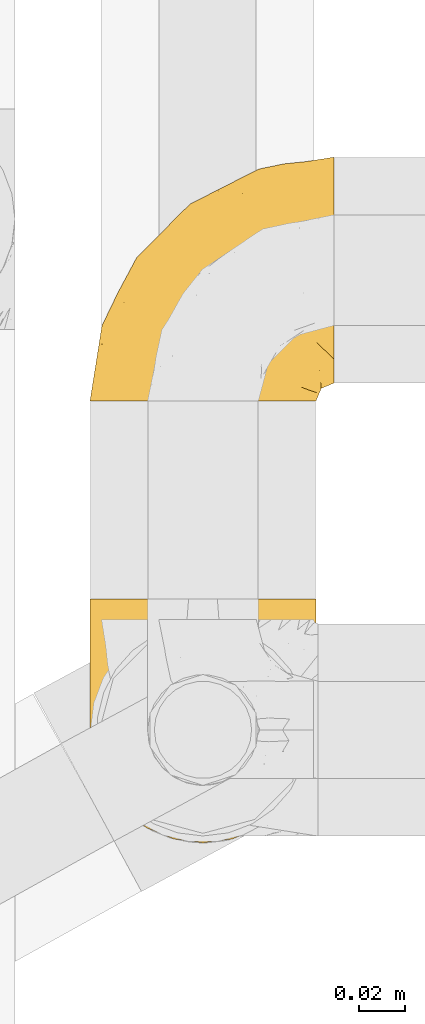
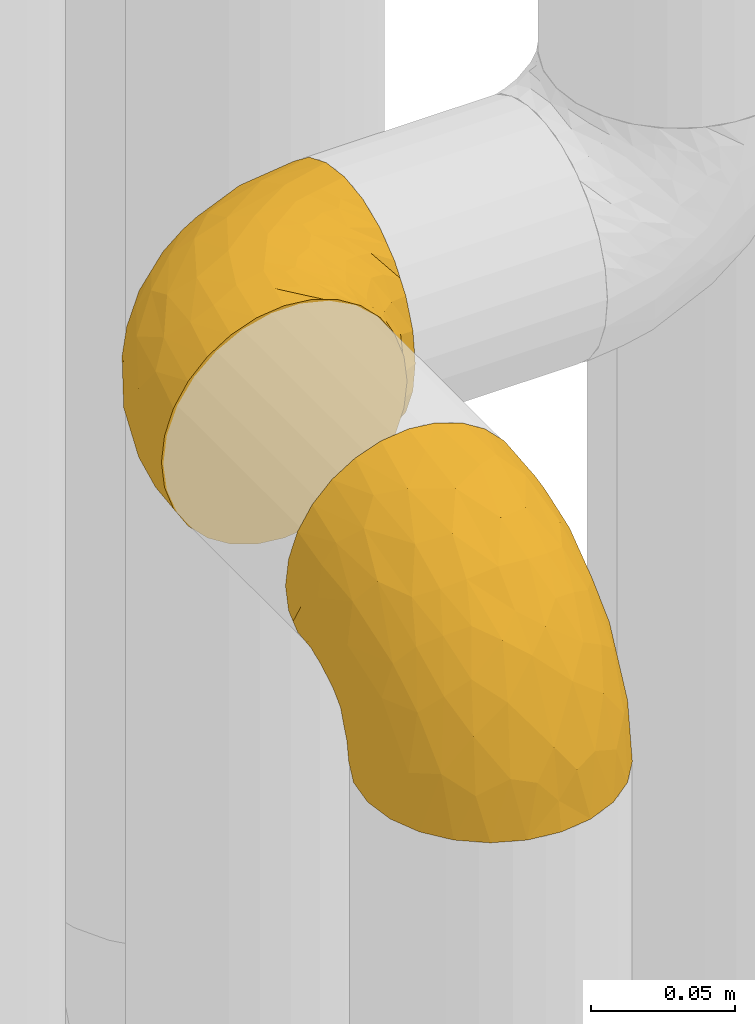
# One storey, part 147 of 827: 2 coverings.
"""IFC2X3 building model written with IfcOpenShell, lengths in millimetres."""

from ifc_helpers import new_model, entity, si_unit, converted_unit, derived_unit, direction, frame, origin, place, context, subcontext, project, spatial, faceted_brep, element, save


model = new_model("IFC2X3")

# Units and contexts
model_context = context("Model", 3, precision=0.01, world=origin(), true_north=direction((6.12303176911189e-17, 1.0)))
body_context = subcontext(model_context, "Body", "Model", "MODEL_VIEW")
ifc_project = project(units=[si_unit("LENGTHUNIT", "METRE", prefix="MILLI"), si_unit("AREAUNIT", "SQUARE_METRE"), si_unit("VOLUMEUNIT", "CUBIC_METRE"), converted_unit("PLANEANGLEUNIT", "DEGREE", entity("IfcRatioMeasure", 0.0174532925199433), si_unit("PLANEANGLEUNIT", "RADIAN"), dimensions=[0, 0, 0, 0, 0, 0, 0]), si_unit("MASSUNIT", "GRAM", prefix="KILO"), derived_unit("MASSDENSITYUNIT", [(si_unit("MASSUNIT", "GRAM", prefix="KILO"), 1), (si_unit("LENGTHUNIT", "METRE"), -3)]), derived_unit("MOMENTOFINERTIAUNIT", [(si_unit("LENGTHUNIT", "METRE"), 4)]), si_unit("TIMEUNIT", "SECOND"), si_unit("FREQUENCYUNIT", "HERTZ"), si_unit("THERMODYNAMICTEMPERATUREUNIT", "DEGREE_CELSIUS"), derived_unit("THERMALTRANSMITTANCEUNIT", [(si_unit("MASSUNIT", "GRAM", prefix="KILO"), 1), (si_unit("THERMODYNAMICTEMPERATUREUNIT", "KELVIN"), -1), (si_unit("TIMEUNIT", "SECOND"), -3)]), derived_unit("VOLUMETRICFLOWRATEUNIT", [(si_unit("LENGTHUNIT", "METRE"), 3), (si_unit("TIMEUNIT", "SECOND"), -1)]), derived_unit("MASSFLOWRATEUNIT", [(si_unit("MASSUNIT", "GRAM", prefix="KILO"), 1), (si_unit("TIMEUNIT", "SECOND"), -1)]), derived_unit("ROTATIONALFREQUENCYUNIT", [(si_unit("TIMEUNIT", "SECOND"), -1)]), si_unit("ELECTRICCURRENTUNIT", "AMPERE"), si_unit("ELECTRICVOLTAGEUNIT", "VOLT"), si_unit("POWERUNIT", "WATT"), si_unit("FORCEUNIT", "NEWTON", prefix="KILO"), si_unit("ILLUMINANCEUNIT", "LUX"), si_unit("LUMINOUSFLUXUNIT", "LUMEN"), si_unit("LUMINOUSINTENSITYUNIT", "CANDELA"), derived_unit("USERDEFINED", [(si_unit("MASSUNIT", "GRAM", prefix="KILO"), -1), (si_unit("LENGTHUNIT", "METRE"), -2), (si_unit("TIMEUNIT", "SECOND"), 3), (si_unit("LUMINOUSFLUXUNIT", "LUMEN"), 1)]), derived_unit("LINEARVELOCITYUNIT", [(si_unit("LENGTHUNIT", "METRE"), 1), (si_unit("TIMEUNIT", "SECOND"), -1)]), si_unit("PRESSUREUNIT", "PASCAL"), derived_unit("USERDEFINED", [(si_unit("LENGTHUNIT", "METRE"), -2), (si_unit("MASSUNIT", "GRAM", prefix="KILO"), 1), (si_unit("TIMEUNIT", "SECOND"), -2)]), derived_unit("LINEARFORCEUNIT", [(si_unit("MASSUNIT", "GRAM", prefix="KILO"), 1), (si_unit("LENGTHUNIT", "METRE"), 1), (si_unit("TIMEUNIT", "SECOND"), -2), (si_unit("LENGTHUNIT", "METRE"), -1)]), derived_unit("PLANARFORCEUNIT", [(si_unit("MASSUNIT", "GRAM", prefix="KILO"), 1), (si_unit("LENGTHUNIT", "METRE"), 1), (si_unit("TIMEUNIT", "SECOND"), -2), (si_unit("LENGTHUNIT", "METRE"), -2)])], contexts=[model_context])

# Site, building, storey
site_placement = place(None, origin())
site = spatial("IfcSite", under=ifc_project, at=site_placement, CompositionType="ELEMENT")
building_placement = place(site_placement, origin())
building = spatial("IfcBuilding", under=site, at=building_placement, CompositionType="ELEMENT")
storey_placement = place(building_placement, frame((0.0, 0.0, 28200.0)))
storey = spatial("IfcBuildingStorey", under=building, at=storey_placement, Name="08", CompositionType="ELEMENT", Elevation=28200.0)

# Coverings
covering_1_placement = place(storey_placement, frame((35677.3, 10555.46, 2541.4)))
element("IfcCovering", 1, at=covering_1_placement, inside=storey, Name=":ADSK_", ObjectType=":ADSK_", PredefinedType="INSULATION", context=body_context, shape_type="Brep", body=[
    faceted_brep([(1.6, 107.75, 58.6), (2.83, 107.75, 69.54), (6.47, 107.75, 79.93), (12.32, 107.75, 89.25), (20.11, 107.75, 97.03), (29.43, 107.75, 102.88), (39.81, 107.75, 106.51), (50.75, 107.75, 107.75), (61.69, 107.75, 106.51), (72.08, 107.75, 102.87), (81.4, 107.75, 97.02), (89.18, 107.75, 89.23), (95.03, 107.75, 79.91), (98.66, 107.75, 69.53), (99.9, 107.75, 58.6), (99.25, 107.75, 52.89), (98.66, 107.75, 47.65), (96.84, 107.75, 42.46), (95.02, 107.75, 37.26), (89.17, 107.75, 27.94), (81.38, 107.75, 20.16), (72.06, 107.75, 14.31), (61.68, 107.75, 10.68), (50.75, 107.75, 9.45), (39.8, 107.75, 10.68), (29.41, 107.75, 14.32), (20.09, 107.75, 20.17), (12.31, 107.75, 27.96), (6.46, 107.75, 37.28), (4.64, 107.75, 42.47), (2.83, 107.75, 47.66), (2.24, 107.75, 52.89), (1.92, 107.75, 55.75), (63.47, 98.22, 1.6), (75.32, 93.31, 1.6), (80.41, 89.4, 1.6), (85.5, 85.5, 1.6), (89.4, 80.41, 1.6), (93.31, 75.32, 1.6), (95.77, 69.39, 1.6), (98.22, 63.47, 1.6), (99.14, 56.48, 1.6), (99.52, 53.61, 1.6), (99.9, 50.75, 1.6), (98.22, 38.02, 1.6), (93.31, 26.17, 1.6), (85.5, 15.99, 1.6), (75.32, 8.18, 1.6), (63.47, 3.27, 1.6), (50.75, 1.6, 1.6), (38.02, 3.27, 1.6), (26.17, 8.18, 1.6), (15.99, 15.99, 1.6), (8.18, 26.17, 1.6), (3.27, 38.02, 1.6), (1.6, 50.75, 1.6), (2.35, 56.48, 1.6), (3.27, 63.47, 1.6), (5.73, 69.39, 1.6), (8.18, 75.32, 1.6), (12.09, 80.41, 1.6), (15.99, 85.5, 1.6), (21.08, 89.4, 1.6), (26.17, 93.31, 1.6), (38.02, 98.22, 1.6), (50.75, 99.9, 1.6), (42.18, 27.53, 69.96), (28.42, 25.32, 59.59), (37.78, 16.29, 51.96), (50.75, 6.79, 34.4), (42.85, 4.51, 23.37), (50.75, 3.51, 13.68), (24.75, 17.47, 41.52), (33.81, 7.6, 26.26), (22.57, 12.27, 20.18), (7.18, 70.89, 72.33), (2.73, 87.17, 65.88), (3.09, 67.3, 57.55), (6.92, 31.65, 23.76), (11.58, 33.58, 46.5), (5.17, 47.23, 46.57), (2.71, 43.26, 21.17), (1.6, 55.08, 23.41), (1.6, 53.99, 17.92), (1.6, 52.9, 12.43), (1.6, 52.36, 9.72), (1.6, 51.82, 7.01), (14.18, 21.5, 26.77), (5.88, 89.94, 76.59), (41.06, 60.45, 95.55), (36.25, 83.0, 102.57), (28.62, 64.79, 92.89), (1.6, 85.93, 54.26), (1.6, 81.31, 51.17), (1.6, 76.69, 48.08), (1.6, 72.06, 44.99), (1.6, 67.44, 41.9), (10.85, 88.74, 85.16), (38.35, 45.98, 85.97), (9.6, 47.13, 59.58), (26.24, 89.4, 99.5), (50.75, 95.66, 105.83), (19.31, 28.5, 53.59), (16.41, 42.81, 67.0), (24.56, 38.28, 71.56), (50.75, 45.35, 87.47), (50.75, 33.61, 75.73), (18.47, 82.57, 92.24), (1.6, 105.04, 58.06), (1.6, 102.33, 57.52), (1.6, 96.91, 56.44), (1.6, 91.42, 55.35), (14.36, 65.92, 81.33), (20.64, 53.11, 80.35), (2.32, 54.37, 39.44), (50.75, 74.94, 102.55), (1.6, 64.35, 37.28), (1.6, 61.26, 32.65), (1.6, 58.17, 28.03), (50.75, 21.87, 63.99), (33.88, 34.79, 74.55), (29.24, 48.48, 83.62), (50.75, 60.15, 95.01), (50.75, 14.33, 49.19), (2.8, 99.07, 46.96), (2.48, 60.55, 8.77), (2.7, 64.18, 18.28), (3.2, 64.36, 11.68), (32.98, 103.17, 11.79), (24.67, 101.69, 15.69), (2.95, 87.75, 42.49), (2.19, 89.38, 47.41), (17.92, 88.34, 7.94), (12.02, 82.14, 9.27), (25.73, 94.51, 7.98), (16.63, 89.64, 13.4), (25.6, 98.41, 13.04), (36.72, 99.71, 7.36), (10.66, 89.37, 23.46), (6.87, 88.21, 30.46), (11.12, 95.2, 26.54), (10.31, 79.14, 6.76), (12.84, 101.22, 26.46), (17.38, 99.41, 20.77), (9.74, 84.72, 20.68), (4.63, 97.47, 40.26), (50.75, 102.19, 7.15), (42.52, 104.02, 9.28), (3.12, 82.66, 38.78), (17.58, 95.42, 18.27), (3.97, 78.67, 31.78), (5.94, 72.69, 12.75), (2.73, 66.46, 22.96), (6.23, 75.3, 17.55), (3.45, 72.74, 27.63), (10.84, 82.93, 15.23), (7.98, 99.27, 33.25), (7.33, 93.51, 32.43), (2.39, 67.35, 27.9), (75.76, 94.51, 7.97), (90.65, 82.94, 15.22), (83.57, 88.33, 7.93), (84.85, 89.64, 13.38), (71.05, 103.62, 13.12), (98.54, 87.74, 42.49), (99.3, 89.38, 47.4), (99.9, 81.31, 51.17), (96.86, 97.47, 40.24), (84.1, 99.41, 20.76), (99.9, 52.9, 12.43), (99.9, 51.82, 7.01), (99.9, 51.28, 4.31), (88.63, 101.21, 26.44), (90.36, 95.19, 26.52), (98.29, 64.36, 11.68), (95.55, 72.69, 12.75), (89.47, 82.13, 9.27), (95.26, 75.3, 17.55), (91.18, 79.14, 6.76), (93.49, 99.28, 33.21), (94.15, 93.51, 32.41), (99.01, 60.55, 8.77), (98.76, 66.46, 22.96), (98.85, 63.96, 18.48), (99.9, 96.91, 56.44), (98.69, 99.06, 46.95), (64.78, 99.7, 7.36), (99.9, 53.99, 17.92), (99.9, 55.08, 23.41), (62.91, 103.3, 9.85), (99.9, 102.33, 57.52), (99.9, 99.62, 56.98), (99.9, 76.69, 48.08), (98.37, 82.66, 38.78), (83.9, 95.42, 18.25), (99.9, 72.06, 44.99), (97.51, 78.68, 31.74), (94.62, 88.2, 30.45), (98.04, 72.75, 27.63), (91.73, 84.74, 20.65), (99.9, 91.42, 55.35), (99.9, 85.93, 54.26), (75.87, 98.41, 13.03), (90.83, 89.37, 23.44), (99.1, 67.35, 27.9), (99.9, 61.26, 32.65), (99.9, 58.17, 28.03), (99.9, 64.35, 37.28), (99.9, 67.44, 41.9), (99.09, 54.08, 39.74), (58.64, 4.51, 23.37), (87.31, 21.5, 26.77), (89.93, 33.43, 46.18), (82.22, 28.5, 53.54), (76.74, 17.47, 41.53), (73.12, 25.36, 59.61), (95.54, 90.18, 76.79), (98.7, 86.97, 66.11), (98.79, 43.26, 21.17), (63.71, 16.29, 51.96), (67.68, 7.6, 26.26), (78.92, 12.27, 20.18), (94.57, 31.65, 23.76), (72.88, 64.79, 92.88), (65.25, 83.0, 102.57), (60.44, 60.44, 95.54), (76.94, 38.35, 71.63), (67.61, 34.8, 74.55), (94.38, 71.54, 72.51), (59.31, 27.53, 69.96), (83.03, 82.57, 92.23), (90.66, 88.74, 85.15), (80.8, 53.19, 80.45), (72.22, 48.49, 83.65), (98.39, 67.28, 57.57), (92.31, 52.32, 63.68), (63.11, 45.94, 85.95), (75.27, 89.4, 99.49), (87.15, 65.75, 81.23), (96.03, 46.73, 47.07), (85.1, 42.82, 66.99)], [[[0, 1, 2, 3, 4, 5, 6, 7, 8, 9, 10, 11, 12, 13, 14, 15, 16, 17, 18, 19, 20, 21, 22, 23, 24, 25, 26, 27, 28, 29, 30, 31, 32]], [[33, 34, 35, 36, 37, 38, 39, 40, 41, 42, 43, 44, 45, 46, 47, 48, 49, 50, 51, 52, 53, 54, 55, 56, 57, 58, 59, 60, 61, 62, 63, 64, 65]], [[66, 67, 68]], [[69, 70, 71]], [[68, 72, 73]], [[73, 72, 74]], [[75, 76, 77]], [[78, 79, 80]], [[51, 50, 73]], [[81, 82, 83, 84, 85, 86, 55]], [[52, 87, 53]], [[74, 52, 51]], [[2, 1, 88]], [[89, 90, 91]], [[77, 92, 93, 94, 95, 96]], [[55, 54, 81]], [[78, 53, 87]], [[5, 90, 6]], [[88, 76, 75]], [[97, 3, 2]], [[89, 91, 98]], [[99, 80, 79]], [[90, 5, 100]], [[74, 87, 52]], [[100, 5, 4]], [[90, 101, 6]], [[79, 102, 103]], [[102, 67, 104]], [[105, 98, 106]], [[107, 4, 3]], [[76, 0, 108, 109, 110, 111, 92]], [[107, 112, 113]], [[114, 77, 96]], [[89, 115, 90]], [[114, 96, 116, 117, 118, 82]], [[75, 97, 88]], [[119, 66, 68]], [[50, 71, 70]], [[100, 91, 90]], [[99, 77, 80]], [[102, 104, 103]], [[97, 107, 3]], [[80, 81, 78]], [[107, 97, 112]], [[68, 73, 70]], [[66, 98, 120]], [[78, 81, 54]], [[114, 81, 80]], [[53, 78, 54]], [[78, 87, 79]], [[102, 87, 72]], [[79, 103, 99]], [[4, 107, 100]], [[91, 100, 107]], [[88, 97, 2]], [[112, 97, 75]], [[99, 112, 75]], [[103, 104, 113]], [[91, 121, 98]], [[89, 105, 122, 115]], [[101, 90, 115]], [[101, 7, 6]], [[88, 1, 76]], [[0, 76, 1]], [[92, 77, 76]], [[73, 74, 51]], [[87, 74, 72]], [[81, 114, 82]], [[77, 114, 80]], [[87, 102, 79]], [[67, 102, 72]], [[68, 67, 72]], [[67, 120, 104]], [[120, 121, 104]], [[104, 121, 113]], [[121, 120, 98]], [[91, 107, 113]], [[91, 113, 121]], [[103, 113, 112]], [[106, 98, 66]], [[105, 89, 98]], [[106, 66, 119]], [[67, 66, 120]], [[68, 69, 123, 119]], [[50, 49, 71]], [[50, 70, 73]], [[112, 99, 103]], [[77, 99, 75]], [[69, 68, 70]], [[29, 124, 110]], [[84, 83, 125]], [[126, 82, 118]], [[59, 58, 127]], [[25, 128, 129]], [[130, 93, 131]], [[132, 62, 133]], [[134, 135, 136]], [[137, 65, 64]], [[64, 134, 137]], [[138, 139, 140]], [[111, 110, 124, 92]], [[134, 136, 137]], [[134, 64, 63]], [[141, 61, 60]], [[125, 58, 57]], [[142, 143, 140]], [[142, 26, 143]], [[127, 83, 82]], [[28, 124, 29]], [[108, 0, 32, 31, 30, 110, 109]], [[30, 29, 110]], [[135, 144, 138]], [[28, 145, 124]], [[57, 56, 55, 86, 85, 84]], [[146, 147, 23]], [[24, 23, 147]], [[25, 143, 26]], [[95, 94, 148]], [[24, 128, 25]], [[149, 138, 143]], [[124, 145, 131]], [[127, 58, 125]], [[150, 148, 139]], [[127, 126, 151]], [[151, 59, 127]], [[152, 151, 126]], [[153, 154, 155]], [[153, 133, 141]], [[145, 28, 27]], [[142, 156, 27]], [[157, 148, 130]], [[61, 133, 62]], [[134, 132, 135]], [[147, 128, 24]], [[65, 137, 146]], [[146, 137, 147]], [[128, 137, 136]], [[137, 128, 147]], [[128, 136, 129]], [[149, 129, 136]], [[25, 129, 143]], [[158, 152, 117]], [[152, 118, 117]], [[153, 151, 152]], [[158, 116, 154]], [[144, 150, 138]], [[153, 152, 158]], [[133, 153, 155]], [[133, 155, 132]], [[141, 60, 151]], [[135, 132, 155]], [[134, 63, 132]], [[144, 135, 155]], [[135, 138, 149]], [[155, 154, 144]], [[150, 154, 96]], [[154, 150, 144]], [[148, 94, 130]], [[82, 126, 127]], [[118, 152, 126]], [[150, 96, 95]], [[139, 148, 157]], [[150, 95, 148]], [[93, 92, 131]], [[130, 145, 156]], [[130, 94, 93]], [[84, 125, 57]], [[127, 125, 83]], [[140, 139, 157]], [[150, 139, 138]], [[140, 157, 142]], [[138, 140, 143]], [[156, 142, 157]], [[27, 26, 142]], [[130, 156, 157]], [[145, 27, 156]], [[132, 63, 62]], [[124, 131, 92]], [[130, 131, 145]], [[129, 149, 143]], [[135, 149, 136]], [[153, 141, 151]], [[59, 151, 60]], [[133, 61, 141]], [[116, 96, 154]], [[153, 158, 154]], [[158, 117, 116]], [[34, 33, 159]], [[160, 161, 162]], [[22, 21, 163]], [[164, 165, 166]], [[19, 18, 167]], [[168, 21, 20]], [[42, 41, 40, 169, 170, 171, 43]], [[172, 173, 168]], [[174, 38, 175]], [[176, 177, 178]], [[179, 164, 180]], [[40, 181, 169]], [[182, 183, 175]], [[17, 184, 185]], [[65, 146, 186]], [[187, 174, 188]], [[23, 22, 189]], [[174, 39, 38]], [[15, 14, 190, 191, 184, 16]], [[181, 40, 39]], [[192, 193, 164]], [[194, 163, 168]], [[33, 186, 159]], [[180, 173, 172]], [[195, 196, 193]], [[18, 185, 167]], [[173, 180, 197]], [[198, 199, 196]], [[200, 201, 185, 184]], [[184, 17, 16]], [[18, 17, 185]], [[202, 159, 186]], [[194, 168, 203]], [[189, 163, 202]], [[204, 205, 182]], [[187, 181, 174]], [[160, 177, 176]], [[206, 183, 182]], [[206, 182, 205]], [[201, 165, 185]], [[165, 164, 167]], [[172, 179, 180]], [[202, 194, 162]], [[176, 161, 160]], [[65, 186, 33]], [[163, 189, 22]], [[175, 177, 182]], [[174, 183, 188]], [[177, 198, 204]], [[199, 160, 162]], [[198, 207, 204]], [[175, 38, 37]], [[198, 177, 160]], [[178, 177, 175]], [[176, 35, 161]], [[34, 159, 161]], [[162, 161, 159]], [[202, 162, 159]], [[199, 162, 203]], [[196, 199, 203]], [[198, 160, 199]], [[193, 197, 180]], [[208, 198, 196]], [[188, 183, 206]], [[175, 183, 174]], [[193, 192, 195]], [[195, 208, 196]], [[197, 196, 203]], [[180, 164, 193]], [[168, 163, 21]], [[166, 165, 201]], [[166, 192, 164]], [[189, 202, 186]], [[186, 146, 189]], [[23, 189, 146]], [[174, 181, 39]], [[169, 181, 187]], [[196, 197, 193]], [[173, 203, 168]], [[203, 173, 197]], [[172, 168, 20]], [[20, 19, 172]], [[179, 172, 19]], [[19, 167, 179]], [[164, 179, 167]], [[35, 176, 36]], [[35, 34, 161]], [[185, 165, 167]], [[162, 194, 203]], [[163, 194, 202]], [[176, 178, 36]], [[37, 36, 178]], [[175, 37, 178]], [[177, 204, 182]], [[207, 198, 208]], [[207, 205, 204]], [[209, 188, 206, 205, 207, 208]], [[48, 210, 71]], [[211, 212, 213]], [[214, 213, 215]], [[216, 217, 13]], [[218, 43, 171, 170, 169, 187, 188]], [[219, 220, 214]], [[47, 46, 221]], [[210, 48, 220]], [[211, 222, 212]], [[222, 45, 44]], [[221, 220, 47]], [[47, 220, 48]], [[221, 211, 214]], [[223, 224, 225]], [[211, 46, 45]], [[226, 227, 215]], [[43, 218, 44]], [[217, 216, 228]], [[219, 215, 229]], [[14, 13, 217]], [[224, 9, 8]], [[10, 230, 11]], [[11, 231, 12]], [[232, 223, 233]], [[234, 208, 195, 192, 166, 201]], [[235, 234, 228]], [[222, 44, 218]], [[106, 229, 236]], [[224, 237, 9]], [[231, 238, 228]], [[9, 237, 10]], [[115, 224, 101]], [[239, 234, 235]], [[231, 11, 230]], [[223, 230, 237]], [[224, 8, 101]], [[223, 236, 233]], [[225, 115, 122, 105]], [[216, 12, 231]], [[209, 234, 239]], [[210, 219, 69]], [[219, 214, 215]], [[229, 119, 219]], [[209, 218, 188]], [[239, 212, 222]], [[239, 222, 218]], [[45, 222, 211]], [[235, 212, 239]], [[213, 212, 240]], [[223, 237, 224]], [[230, 10, 237]], [[238, 231, 230]], [[216, 231, 228]], [[232, 230, 223]], [[235, 238, 240]], [[115, 225, 224]], [[233, 236, 227]], [[8, 7, 101]], [[234, 209, 208]], [[218, 209, 239]], [[217, 228, 234]], [[13, 12, 216]], [[234, 201, 217]], [[217, 201, 200, 184, 191, 190, 14]], [[211, 221, 46]], [[220, 221, 214]], [[71, 210, 69]], [[71, 49, 48]], [[219, 210, 220]], [[226, 215, 213]], [[211, 213, 214]], [[226, 213, 240]], [[215, 227, 229]], [[232, 240, 238]], [[233, 227, 226]], [[232, 233, 226]], [[236, 223, 225]], [[240, 232, 226]], [[232, 238, 230]], [[225, 105, 236]], [[236, 105, 106]], [[236, 229, 227]], [[123, 69, 219, 119]], [[106, 119, 229]], [[238, 235, 228]], [[212, 235, 240]]]),
])
covering_2_placement = place(storey_placement, frame((35677.3, 10747.61, 2549.25)))
element("IfcCovering", 2, at=covering_2_placement, inside=storey, Name=":ADSK_", ObjectType=":ADSK_", PredefinedType="INSULATION", context=body_context, shape_type="Brep", body=[
    faceted_brep([(50.75, 1.6, 99.9), (39.8, 1.6, 98.66), (29.41, 1.6, 95.02), (20.09, 1.6, 89.17), (12.31, 1.6, 81.38), (6.46, 1.6, 72.06), (2.83, 1.6, 61.68), (1.6, 1.6, 50.75), (2.83, 1.6, 39.8), (6.47, 1.6, 29.41), (12.32, 1.6, 20.09), (20.11, 1.6, 12.31), (29.43, 1.6, 6.46), (39.81, 1.6, 2.83), (50.75, 1.6, 1.6), (56.45, 1.6, 2.24), (61.69, 1.6, 2.83), (66.88, 1.6, 4.65), (72.08, 1.6, 6.47), (81.4, 1.6, 12.32), (89.18, 1.6, 20.11), (95.03, 1.6, 29.43), (98.66, 1.6, 39.81), (99.9, 1.6, 50.75), (98.66, 1.6, 61.69), (95.02, 1.6, 72.08), (89.17, 1.6, 81.4), (81.38, 1.6, 89.18), (72.06, 1.6, 95.03), (66.87, 1.6, 96.85), (61.68, 1.6, 98.66), (56.45, 1.6, 99.25), (53.6, 1.6, 99.57), (107.75, 11.12, 38.02), (107.75, 16.03, 26.17), (107.75, 19.94, 21.08), (107.75, 23.84, 15.99), (107.75, 28.93, 12.09), (107.75, 34.02, 8.18), (107.75, 39.95, 5.73), (107.75, 45.87, 3.27), (107.75, 52.86, 2.35), (107.75, 55.73, 1.97), (107.75, 58.6, 1.6), (107.75, 71.32, 3.27), (107.75, 83.17, 8.18), (107.75, 93.35, 15.99), (107.75, 101.16, 26.17), (107.75, 106.07, 38.02), (107.75, 107.75, 50.75), (107.75, 106.07, 63.47), (107.75, 101.16, 75.32), (107.75, 93.35, 85.5), (107.75, 83.17, 93.31), (107.75, 71.32, 98.22), (107.75, 58.6, 99.9), (107.75, 52.86, 99.14), (107.75, 45.87, 98.22), (107.75, 39.95, 95.77), (107.75, 34.02, 93.31), (107.75, 28.93, 89.4), (107.75, 23.84, 85.5), (107.75, 19.94, 80.41), (107.75, 16.03, 75.32), (107.75, 11.12, 63.47), (107.75, 9.45, 50.75), (39.38, 81.82, 59.31), (49.75, 84.02, 73.08), (57.38, 93.05, 63.72), (74.94, 102.55, 50.75), (85.97, 104.83, 58.64), (95.66, 105.83, 50.75), (67.82, 91.87, 76.74), (83.09, 101.74, 67.68), (89.16, 97.07, 78.92), (37.01, 38.45, 94.31), (43.46, 22.17, 98.76), (51.79, 42.04, 98.4), (85.58, 77.69, 94.57), (62.84, 75.76, 89.91), (62.77, 62.11, 96.32), (88.17, 66.08, 98.79), (85.93, 54.26, 99.9), (91.42, 55.35, 99.9), (96.91, 56.44, 99.9), (99.62, 56.98, 99.9), (102.33, 57.52, 99.9), (82.57, 87.84, 87.31), (32.75, 19.41, 95.61), (13.79, 48.89, 60.43), (6.77, 26.34, 65.24), (16.46, 44.55, 72.87), (55.08, 23.41, 99.9), (58.17, 28.03, 99.9), (61.26, 32.65, 99.9), (64.35, 37.28, 99.9), (67.44, 41.9, 99.9), (24.18, 20.6, 90.65), (23.37, 63.36, 63.14), (49.76, 62.21, 91.89), (9.84, 19.94, 75.25), (3.51, 13.68, 50.75), (55.75, 80.85, 82.18), (42.34, 66.53, 85.08), (37.78, 71.06, 76.93), (21.87, 63.99, 50.75), (33.61, 75.73, 50.75), (17.1, 26.77, 83.02), (51.28, 4.31, 99.9), (51.82, 7.01, 99.9), (52.9, 12.43, 99.9), (53.99, 17.92, 99.9), (28.01, 43.43, 87.13), (28.99, 56.23, 80.85), (69.9, 54.97, 99.17), (6.79, 34.4, 50.75), (72.06, 44.99, 99.9), (76.69, 48.08, 99.9), (81.31, 51.17, 99.9), (45.35, 87.47, 50.75), (34.79, 74.55, 67.61), (25.72, 60.86, 72.25), (14.33, 49.19, 50.75), (60.15, 95.01, 50.75), (62.38, 10.27, 98.69), (100.57, 48.79, 99.01), (91.06, 45.16, 98.79), (97.66, 44.99, 98.29), (97.55, 6.17, 68.51), (93.65, 7.65, 76.82), (66.85, 21.59, 98.54), (61.93, 19.96, 99.3), (101.4, 21.0, 83.57), (100.07, 27.2, 89.47), (101.36, 14.83, 75.76), (95.94, 19.7, 84.86), (96.3, 10.93, 75.89), (101.98, 9.63, 64.77), (85.88, 19.97, 90.83), (78.88, 21.13, 94.62), (82.8, 14.14, 90.37), (102.58, 30.2, 91.18), (82.88, 8.12, 88.65), (88.57, 9.93, 84.11), (88.67, 24.62, 91.75), (69.08, 11.87, 96.86), (102.19, 7.15, 50.75), (100.06, 5.32, 58.97), (70.56, 26.68, 98.37), (91.07, 13.92, 83.91), (77.56, 30.67, 97.52), (96.59, 36.65, 95.55), (86.38, 42.89, 98.76), (91.79, 34.04, 95.26), (81.71, 36.6, 98.04), (94.11, 26.41, 90.65), (76.09, 10.07, 93.51), (76.91, 15.83, 94.16), (81.44, 41.99, 99.1), (101.37, 14.83, 25.73), (94.12, 26.4, 10.84), (101.41, 21.01, 17.92), (95.96, 19.71, 16.64), (96.22, 5.72, 30.44), (66.85, 21.6, 2.95), (61.94, 19.96, 2.19), (58.17, 28.03, 1.6), (69.1, 11.87, 4.63), (88.58, 9.93, 17.39), (96.91, 56.44, 1.6), (102.33, 57.52, 1.6), (105.04, 58.06, 1.6), (82.9, 8.13, 12.86), (82.82, 14.15, 11.13), (97.66, 44.99, 3.2), (96.59, 36.65, 5.94), (100.07, 27.21, 12.02), (91.79, 34.04, 6.23), (102.58, 30.2, 10.31), (76.13, 10.06, 8.0), (76.93, 15.83, 7.34), (100.57, 48.79, 2.48), (86.38, 42.89, 2.73), (90.86, 45.38, 2.64), (52.9, 12.43, 1.6), (62.39, 10.28, 2.8), (101.98, 9.64, 36.71), (91.42, 55.35, 1.6), (85.93, 54.26, 1.6), (99.49, 6.05, 38.59), (51.82, 7.01, 1.6), (52.36, 9.72, 1.6), (61.26, 32.65, 1.6), (70.56, 26.68, 3.12), (91.09, 13.92, 17.59), (64.35, 37.28, 1.6), (77.6, 30.66, 3.98), (78.89, 21.14, 6.87), (81.71, 36.59, 3.45), (88.69, 24.6, 9.76), (53.99, 17.92, 1.6), (55.08, 23.41, 1.6), (96.31, 10.93, 25.62), (85.9, 19.97, 10.67), (81.45, 41.99, 2.39), (76.69, 48.08, 1.6), (81.31, 51.17, 1.6), (72.06, 44.99, 1.6), (67.44, 41.9, 1.6), (69.6, 55.26, 2.4), (85.97, 104.83, 42.85), (82.57, 87.84, 14.18), (63.16, 75.91, 11.56), (55.81, 80.84, 19.27), (67.81, 91.87, 24.75), (49.73, 83.98, 28.37), (32.55, 19.16, 5.95), (43.23, 22.37, 2.79), (88.17, 66.08, 2.71), (57.38, 93.05, 37.78), (83.08, 101.74, 33.81), (89.16, 97.07, 22.57), (85.58, 77.69, 6.92), (16.46, 44.55, 28.61), (6.77, 26.34, 36.24), (13.8, 48.9, 41.05), (37.71, 70.99, 24.55), (34.8, 74.55, 33.88), (36.83, 37.8, 7.11), (39.38, 81.82, 42.18), (17.12, 26.77, 18.46), (24.19, 20.6, 10.84), (28.89, 56.15, 20.69), (25.69, 60.85, 29.27), (51.77, 42.06, 3.1), (45.66, 57.03, 9.18), (23.39, 63.4, 38.38), (9.85, 19.94, 26.23), (28.11, 43.59, 14.34), (62.27, 62.61, 5.46), (42.35, 66.52, 16.39)], [[[0, 1, 2, 3, 4, 5, 6, 7, 8, 9, 10, 11, 12, 13, 14, 15, 16, 17, 18, 19, 20, 21, 22, 23, 24, 25, 26, 27, 28, 29, 30, 31, 32]], [[33, 34, 35, 36, 37, 38, 39, 40, 41, 42, 43, 44, 45, 46, 47, 48, 49, 50, 51, 52, 53, 54, 55, 56, 57, 58, 59, 60, 61, 62, 63, 64, 65]], [[66, 67, 68]], [[69, 70, 71]], [[68, 72, 73]], [[73, 72, 74]], [[75, 76, 77]], [[78, 79, 80]], [[51, 50, 73]], [[81, 82, 83, 84, 85, 86, 55]], [[52, 87, 53]], [[74, 52, 51]], [[2, 1, 88]], [[89, 90, 91]], [[77, 92, 93, 94, 95, 96]], [[55, 54, 81]], [[78, 53, 87]], [[5, 90, 6]], [[88, 76, 75]], [[97, 3, 2]], [[89, 91, 98]], [[99, 80, 79]], [[90, 5, 100]], [[74, 87, 52]], [[100, 5, 4]], [[90, 101, 6]], [[79, 102, 103]], [[102, 67, 104]], [[105, 98, 106]], [[107, 4, 3]], [[76, 0, 108, 109, 110, 111, 92]], [[107, 112, 113]], [[114, 77, 96]], [[89, 115, 90]], [[114, 96, 116, 117, 118, 82]], [[75, 97, 88]], [[119, 66, 68]], [[50, 71, 70]], [[100, 91, 90]], [[99, 77, 80]], [[102, 104, 103]], [[97, 107, 3]], [[80, 81, 78]], [[107, 97, 112]], [[68, 73, 70]], [[66, 98, 120]], [[78, 81, 54]], [[114, 81, 80]], [[53, 78, 54]], [[78, 87, 79]], [[102, 87, 72]], [[79, 103, 99]], [[4, 107, 100]], [[91, 100, 107]], [[88, 97, 2]], [[112, 97, 75]], [[99, 112, 75]], [[103, 104, 113]], [[91, 121, 98]], [[89, 105, 122, 115]], [[101, 90, 115]], [[101, 7, 6]], [[88, 1, 76]], [[0, 76, 1]], [[92, 77, 76]], [[73, 74, 51]], [[87, 74, 72]], [[81, 114, 82]], [[77, 114, 80]], [[87, 102, 79]], [[67, 102, 72]], [[68, 67, 72]], [[67, 120, 104]], [[120, 121, 104]], [[104, 121, 113]], [[121, 120, 98]], [[91, 107, 113]], [[91, 113, 121]], [[103, 113, 112]], [[106, 98, 66]], [[105, 89, 98]], [[106, 66, 119]], [[67, 66, 120]], [[68, 69, 123, 119]], [[50, 49, 71]], [[50, 70, 73]], [[112, 99, 103]], [[77, 99, 75]], [[69, 68, 70]], [[29, 124, 110]], [[84, 83, 125]], [[126, 82, 118]], [[59, 58, 127]], [[25, 128, 129]], [[130, 93, 131]], [[132, 62, 133]], [[134, 135, 136]], [[137, 65, 64]], [[64, 134, 137]], [[138, 139, 140]], [[111, 110, 124, 92]], [[134, 136, 137]], [[134, 64, 63]], [[141, 61, 60]], [[125, 58, 57]], [[142, 143, 140]], [[142, 26, 143]], [[127, 83, 82]], [[28, 124, 29]], [[108, 0, 32, 31, 30, 110, 109]], [[30, 29, 110]], [[135, 144, 138]], [[28, 145, 124]], [[57, 56, 55, 86, 85, 84]], [[146, 147, 23]], [[24, 23, 147]], [[25, 143, 26]], [[95, 94, 148]], [[24, 128, 25]], [[149, 138, 143]], [[124, 145, 131]], [[127, 58, 125]], [[150, 148, 139]], [[127, 126, 151]], [[151, 59, 127]], [[152, 151, 126]], [[153, 154, 155]], [[153, 133, 141]], [[145, 28, 27]], [[142, 156, 27]], [[157, 148, 130]], [[61, 133, 62]], [[134, 132, 135]], [[147, 128, 24]], [[65, 137, 146]], [[146, 137, 147]], [[128, 137, 136]], [[137, 128, 147]], [[128, 136, 129]], [[149, 129, 136]], [[25, 129, 143]], [[158, 152, 117]], [[152, 118, 117]], [[153, 151, 152]], [[158, 116, 154]], [[144, 150, 138]], [[153, 152, 158]], [[133, 153, 155]], [[133, 155, 132]], [[60, 151, 141]], [[135, 132, 155]], [[134, 63, 132]], [[144, 135, 155]], [[135, 138, 149]], [[155, 154, 144]], [[150, 154, 96]], [[154, 150, 144]], [[148, 94, 130]], [[82, 126, 127]], [[118, 152, 126]], [[150, 96, 95]], [[139, 148, 157]], [[150, 95, 148]], [[93, 92, 131]], [[130, 145, 156]], [[130, 94, 93]], [[84, 125, 57]], [[127, 125, 83]], [[140, 139, 157]], [[150, 139, 138]], [[140, 157, 142]], [[138, 140, 143]], [[156, 142, 157]], [[27, 26, 142]], [[130, 156, 157]], [[145, 27, 156]], [[132, 63, 62]], [[124, 131, 92]], [[130, 131, 145]], [[129, 149, 143]], [[135, 149, 136]], [[141, 133, 61]], [[60, 59, 151]], [[141, 151, 153]], [[116, 96, 154]], [[153, 158, 154]], [[158, 117, 116]], [[34, 33, 159]], [[160, 161, 162]], [[22, 21, 163]], [[164, 165, 166]], [[19, 18, 167]], [[168, 21, 20]], [[42, 41, 40, 169, 170, 171, 43]], [[172, 173, 168]], [[174, 38, 175]], [[176, 177, 178]], [[179, 164, 180]], [[40, 181, 169]], [[182, 183, 175]], [[17, 184, 185]], [[65, 146, 186]], [[187, 174, 188]], [[23, 22, 189]], [[174, 39, 38]], [[15, 14, 190, 191, 184, 16]], [[181, 40, 39]], [[192, 193, 164]], [[194, 163, 168]], [[33, 186, 159]], [[180, 173, 172]], [[195, 196, 193]], [[18, 185, 167]], [[173, 180, 197]], [[198, 199, 196]], [[200, 201, 185, 184]], [[184, 17, 16]], [[18, 17, 185]], [[202, 159, 186]], [[194, 168, 203]], [[189, 163, 202]], [[204, 205, 182]], [[187, 181, 174]], [[160, 177, 176]], [[206, 183, 182]], [[206, 182, 205]], [[201, 165, 185]], [[165, 164, 167]], [[172, 179, 180]], [[202, 194, 162]], [[176, 161, 160]], [[65, 186, 33]], [[163, 189, 22]], [[175, 177, 182]], [[174, 183, 188]], [[177, 198, 204]], [[199, 160, 162]], [[198, 207, 204]], [[175, 38, 37]], [[198, 177, 160]], [[178, 177, 175]], [[176, 35, 161]], [[34, 159, 161]], [[162, 161, 159]], [[202, 162, 159]], [[199, 162, 203]], [[196, 199, 203]], [[198, 160, 199]], [[193, 197, 180]], [[208, 198, 196]], [[188, 183, 206]], [[175, 183, 174]], [[193, 192, 195]], [[195, 208, 196]], [[197, 196, 203]], [[180, 164, 193]], [[168, 163, 21]], [[166, 165, 201]], [[166, 192, 164]], [[189, 202, 186]], [[186, 146, 189]], [[23, 189, 146]], [[174, 181, 39]], [[169, 181, 187]], [[196, 197, 193]], [[173, 203, 168]], [[203, 173, 197]], [[172, 168, 20]], [[20, 19, 172]], [[179, 172, 19]], [[19, 167, 179]], [[164, 179, 167]], [[35, 176, 36]], [[35, 34, 161]], [[185, 165, 167]], [[162, 194, 203]], [[163, 194, 202]], [[176, 178, 36]], [[37, 36, 178]], [[175, 37, 178]], [[177, 204, 182]], [[207, 198, 208]], [[207, 205, 204]], [[209, 188, 206, 205, 207, 208]], [[48, 210, 71]], [[211, 212, 213]], [[214, 213, 215]], [[216, 217, 13]], [[218, 43, 171, 170, 169, 187, 188]], [[219, 220, 214]], [[47, 46, 221]], [[210, 48, 220]], [[211, 222, 212]], [[222, 45, 44]], [[221, 220, 47]], [[47, 220, 48]], [[221, 211, 214]], [[223, 224, 225]], [[211, 46, 45]], [[226, 227, 215]], [[43, 218, 44]], [[217, 216, 228]], [[219, 215, 229]], [[14, 13, 217]], [[224, 9, 8]], [[10, 230, 11]], [[11, 231, 12]], [[232, 223, 233]], [[234, 208, 195, 192, 166, 201]], [[235, 234, 228]], [[222, 44, 218]], [[106, 229, 236]], [[224, 237, 9]], [[231, 238, 228]], [[9, 237, 10]], [[115, 224, 101]], [[239, 234, 235]], [[231, 11, 230]], [[223, 230, 237]], [[224, 8, 101]], [[223, 236, 233]], [[225, 115, 122, 105]], [[216, 12, 231]], [[209, 234, 239]], [[210, 219, 69]], [[219, 214, 215]], [[229, 119, 219]], [[209, 218, 188]], [[239, 212, 222]], [[239, 222, 218]], [[45, 222, 211]], [[235, 212, 239]], [[213, 212, 240]], [[223, 237, 224]], [[230, 10, 237]], [[238, 231, 230]], [[216, 231, 228]], [[232, 230, 223]], [[235, 238, 240]], [[115, 225, 224]], [[233, 236, 227]], [[8, 7, 101]], [[234, 209, 208]], [[218, 209, 239]], [[217, 228, 234]], [[13, 12, 216]], [[234, 201, 217]], [[217, 201, 200, 184, 191, 190, 14]], [[211, 221, 46]], [[220, 221, 214]], [[71, 210, 69]], [[71, 49, 48]], [[219, 210, 220]], [[226, 215, 213]], [[211, 213, 214]], [[226, 213, 240]], [[215, 227, 229]], [[232, 240, 238]], [[233, 227, 226]], [[232, 233, 226]], [[236, 223, 225]], [[240, 232, 226]], [[232, 238, 230]], [[225, 105, 236]], [[236, 105, 106]], [[236, 229, 227]], [[123, 69, 219, 119]], [[106, 119, 229]], [[238, 235, 228]], [[212, 235, 240]]]),
])

save(model, "model.ifc")
